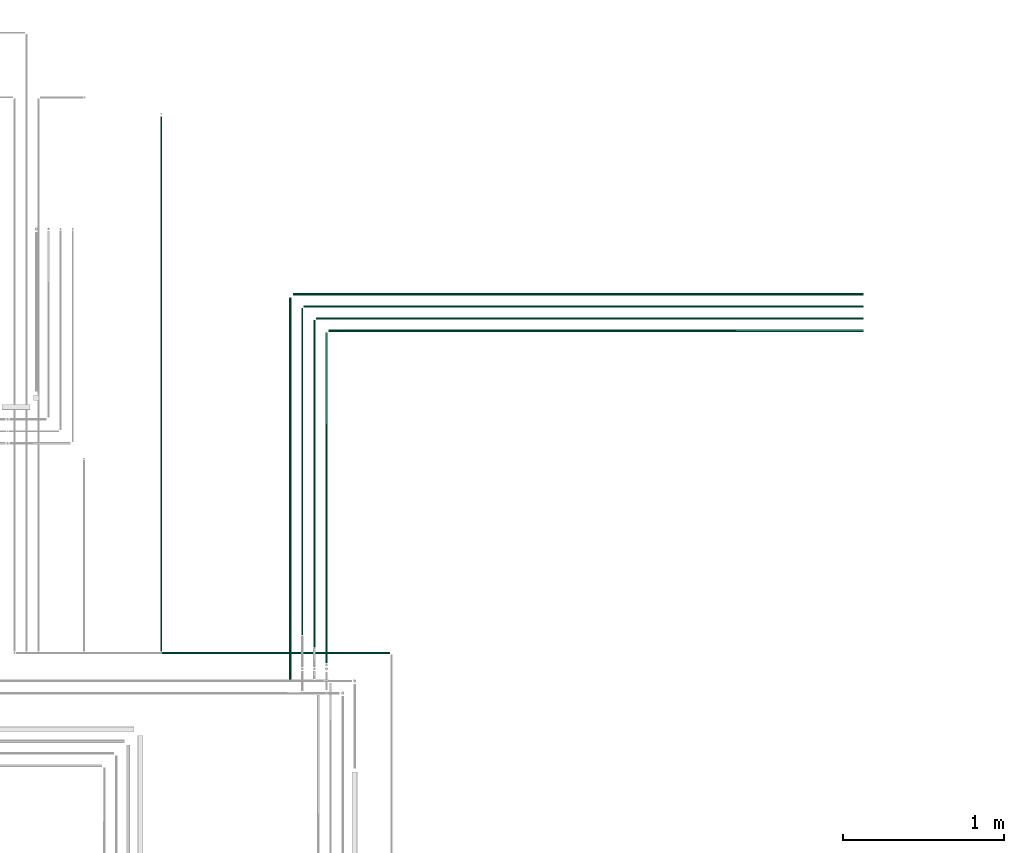
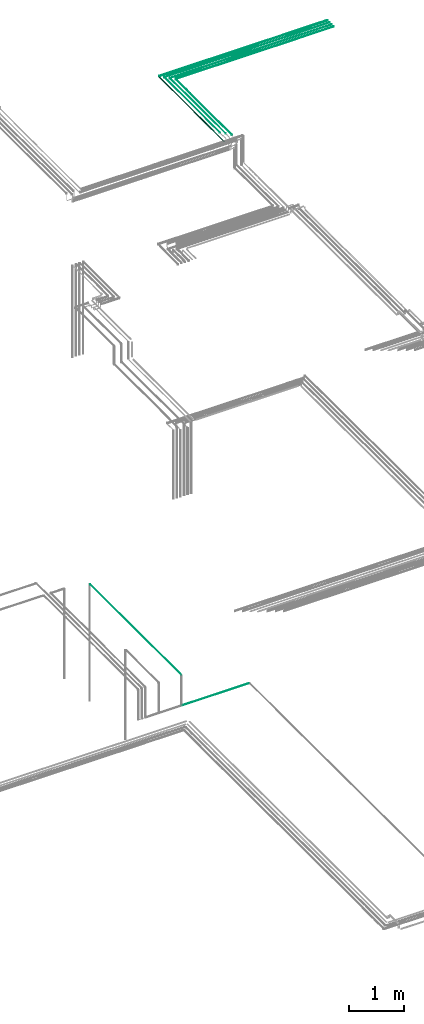
# One storey, part 114 of 331: 10 flow segments.
"""IFC2X3 building model written with IfcOpenShell, lengths in millimetres."""

from ifc_helpers import new_model, entity, si_unit, converted_unit, derived_unit, direction, frame, frame_2d, origin, origin_2d_with_axis, place, context, subcontext, project, spatial, circle, extrude, type_object, element, save


model = new_model("IFC2X3")

# Units and contexts
model_context = context("Model", 3, precision=0.01, world=origin(), true_north=direction((6.12303176911189e-17, 1.0)))
body_context = subcontext(model_context, "Body", "Model", "MODEL_VIEW")
ifc_project = project(units=[si_unit("LENGTHUNIT", "METRE", prefix="MILLI"), si_unit("AREAUNIT", "SQUARE_METRE"), si_unit("VOLUMEUNIT", "CUBIC_METRE"), converted_unit("PLANEANGLEUNIT", "DEGREE", entity("IfcRatioMeasure", 0.0174532925199433), si_unit("PLANEANGLEUNIT", "RADIAN"), dimensions=[0, 0, 0, 0, 0, 0, 0]), si_unit("MASSUNIT", "GRAM", prefix="KILO"), derived_unit("MASSDENSITYUNIT", [(si_unit("MASSUNIT", "GRAM", prefix="KILO"), 1), (si_unit("LENGTHUNIT", "METRE"), -3)]), derived_unit("MOMENTOFINERTIAUNIT", [(si_unit("LENGTHUNIT", "METRE"), 4)]), si_unit("TIMEUNIT", "SECOND"), si_unit("FREQUENCYUNIT", "HERTZ"), si_unit("THERMODYNAMICTEMPERATUREUNIT", "DEGREE_CELSIUS"), derived_unit("THERMALTRANSMITTANCEUNIT", [(si_unit("MASSUNIT", "GRAM", prefix="KILO"), 1), (si_unit("THERMODYNAMICTEMPERATUREUNIT", "KELVIN"), -1), (si_unit("TIMEUNIT", "SECOND"), -3)]), derived_unit("VOLUMETRICFLOWRATEUNIT", [(si_unit("LENGTHUNIT", "METRE"), 3), (si_unit("TIMEUNIT", "SECOND"), -1)]), derived_unit("MASSFLOWRATEUNIT", [(si_unit("MASSUNIT", "GRAM", prefix="KILO"), 1), (si_unit("TIMEUNIT", "SECOND"), -1)]), derived_unit("ROTATIONALFREQUENCYUNIT", [(si_unit("TIMEUNIT", "SECOND"), -1)]), si_unit("ELECTRICCURRENTUNIT", "AMPERE"), si_unit("ELECTRICVOLTAGEUNIT", "VOLT"), si_unit("POWERUNIT", "WATT"), si_unit("FORCEUNIT", "NEWTON", prefix="KILO"), si_unit("ILLUMINANCEUNIT", "LUX"), si_unit("LUMINOUSFLUXUNIT", "LUMEN"), si_unit("LUMINOUSINTENSITYUNIT", "CANDELA"), derived_unit("USERDEFINED", [(si_unit("MASSUNIT", "GRAM", prefix="KILO"), -1), (si_unit("LENGTHUNIT", "METRE"), -2), (si_unit("TIMEUNIT", "SECOND"), 3), (si_unit("LUMINOUSFLUXUNIT", "LUMEN"), 1)]), derived_unit("LINEARVELOCITYUNIT", [(si_unit("LENGTHUNIT", "METRE"), 1), (si_unit("TIMEUNIT", "SECOND"), -1)]), si_unit("PRESSUREUNIT", "PASCAL"), derived_unit("USERDEFINED", [(si_unit("LENGTHUNIT", "METRE"), -2), (si_unit("MASSUNIT", "GRAM", prefix="KILO"), 1), (si_unit("TIMEUNIT", "SECOND"), -2)]), derived_unit("LINEARFORCEUNIT", [(si_unit("MASSUNIT", "GRAM", prefix="KILO"), 1), (si_unit("LENGTHUNIT", "METRE"), 1), (si_unit("TIMEUNIT", "SECOND"), -2), (si_unit("LENGTHUNIT", "METRE"), -1)]), derived_unit("PLANARFORCEUNIT", [(si_unit("MASSUNIT", "GRAM", prefix="KILO"), 1), (si_unit("LENGTHUNIT", "METRE"), 1), (si_unit("TIMEUNIT", "SECOND"), -2), (si_unit("LENGTHUNIT", "METRE"), -2)])], contexts=[model_context])

# Site, building, storey
site_placement = place(None, frame((0.0, -0.00077364408347762, 0.0)))
site = spatial("IfcSite", under=ifc_project, at=site_placement, CompositionType="ELEMENT")
building_placement = place(site_placement, origin())
building = spatial("IfcBuilding", under=site, at=building_placement, CompositionType="ELEMENT")
storey_placement = place(building_placement, origin())
storey = spatial("IfcBuildingStorey", under=building, at=storey_placement, CompositionType="ELEMENT", Elevation=0.0)

# Flow segments
pipe_segment_type = type_object("IfcPipeSegmentType", PredefinedType="NOTDEFINED")
flow_segment_1_placement = place(building_placement, frame((61587.0947663298, 16133.1099669678, 19040.9047277641)))
element("IfcFlowSegment", 1, at=flow_segment_1_placement, inside=storey, type_object=pipe_segment_type, context=body_context, shape_type="SweptSolid", body=[
    extrude(circle(Radius=7.5, at=origin_2d_with_axis()), frame((9.09527223593152, 0.0, 9.09527223591636), z_axis=(0.0, 1.0, 0.0), x_axis=(1.0, 0.0, 0.0)), (0.0, 0.0, 1.0), 2373.88394202706),
])
flow_segment_2_placement = place(building_placement, frame((61614.1900385657, 18515.898636759, 19040.9047277641)))
element("IfcFlowSegment", 2, at=flow_segment_2_placement, inside=storey, type_object=pipe_segment_type, context=body_context, shape_type="SweptSolid", body=[
    extrude(circle(Radius=7.5, at=frame_2d((7.48597324544352e-42, -2.16573425859679e-12), x_axis=(1.0, 0.0))), frame((0.0, 9.09527223593369, 9.09527223591419), z_axis=(1.0, 0.0, 0.0), x_axis=(0.0, -1.0, 0.0)), (0.0, 0.0, 1.0), 3540.80979053584),
])
flow_segment_3_placement = place(storey_placement, frame((61813.5947663298, 16239.1356741211, 19042.4047277641)))
element("IfcFlowSegment", 3, at=flow_segment_3_placement, inside=storey, type_object=pipe_segment_type, context=body_context, shape_type="SweptSolid", body=[
    extrude(circle(Radius=6.0, at=frame_2d((2.59888111031614e-11, 0.0), x_axis=(1.0, 0.0))), frame((7.59527223593186, 0.0, 7.5952722359167), z_axis=(0.0, 1.0, 0.0), x_axis=(-1.0, 0.0, 0.0)), (0.0, 0.0, 1.0), 2046.85823487384),
])
flow_segment_4_placement = place(storey_placement, frame((61740.5947663298, 16334.4521787943, 19044.4047277641)))
element("IfcFlowSegment", 4, at=flow_segment_4_placement, inside=storey, type_object=pipe_segment_type, context=body_context, shape_type="SweptSolid", body=[
    extrude(circle(Radius=4.0, at=frame_2d((8.66293703438714e-12, 0.0), x_axis=(1.0, 0.0))), frame((5.59527223593232, 0.0, 5.59527223591499), z_axis=(0.0, 1.0, 0.0), x_axis=(-1.0, 0.0, 0.0)), (0.0, 0.0, 1.0), 2030.54173020063),
])
flow_segment_5_placement = place(storey_placement, frame((61665.5947663298, 16412.1300733041, 19044.4047277641)))
element("IfcFlowSegment", 5, at=flow_segment_5_placement, inside=storey, type_object=pipe_segment_type, context=body_context, shape_type="SweptSolid", body=[
    extrude(circle(Radius=4.0, at=frame_2d((8.66293703438714e-12, 0.0), x_axis=(1.0, 0.0))), frame((5.59527223593232, 0.0, 5.59527223591499), z_axis=(0.0, 1.0, 0.0), x_axis=(-1.0, 0.0, 0.0)), (0.0, 0.0, 1.0), 2027.86383569082),
])
flow_segment_6_placement = place(building_placement, frame((61835.1900385657, 18292.398636759, 19042.4047277641)))
element("IfcFlowSegment", 6, at=flow_segment_6_placement, inside=storey, type_object=pipe_segment_type, context=body_context, shape_type="SweptSolid", body=[
    extrude(circle(Radius=6.0, at=frame_2d((0.0, 2.16573425859679e-12), x_axis=(1.0, 0.0))), frame((0.0, 7.59527223593403, 7.59527223591887), z_axis=(1.0, 0.0, 0.0), x_axis=(0.0, -1.0, 0.0)), (0.0, 0.0, 1.0), 3319.80979053584),
])
flow_segment_7_placement = place(building_placement, frame((61756.1900385657, 18369.398636759, 19044.4047277641)))
element("IfcFlowSegment", 7, at=flow_segment_7_placement, inside=storey, type_object=pipe_segment_type, context=body_context, shape_type="SweptSolid", body=[
    extrude(circle(Radius=4.0, at=origin_2d_with_axis()), frame((0.0, 5.59527223593232, 5.59527223591499), z_axis=(1.0, 0.0, 0.0), x_axis=(0.0, -1.0, 0.0)), (0.0, 0.0, 1.0), 3398.80979053584),
])
flow_segment_8_placement = place(building_placement, frame((61681.1900385657, 18444.398636759, 19044.4047277641)))
element("IfcFlowSegment", 8, at=flow_segment_8_placement, inside=storey, type_object=pipe_segment_type, context=body_context, shape_type="SweptSolid", body=[
    extrude(circle(Radius=4.0, at=origin_2d_with_axis()), frame((0.0, 5.59527223593232, 5.59527223591499), z_axis=(1.0, 0.0, 0.0), x_axis=(0.0, -1.0, 0.0)), (0.0, 0.0, 1.0), 3473.80979053584),
])
flow_segment_9_placement = place(storey_placement, frame((60789.4049963188, 16308.5068408728, 7344.4047277641)))
element("IfcFlowSegment", 9, at=flow_segment_9_placement, inside=storey, type_object=pipe_segment_type, context=body_context, shape_type="SweptSolid", body=[
    extrude(circle(Radius=4.0, at=frame_2d((0.0, -1.08286712929839e-12), x_axis=(1.0, 0.0))), frame((5.59527223597563, 0.0, 5.59527223591499), z_axis=(0.0, 1.0, 0.0), x_axis=(1.0, 0.0, 0.0)), (0.0, 0.0, 1.0), 3320.79433560841),
])
flow_segment_10_placement = place(building_placement, frame((60800.0002685548, 16292.9115686369, 6669.40472776408)))
element("IfcFlowSegment", 10, at=flow_segment_10_placement, inside=storey, type_object=pipe_segment_type, context=body_context, shape_type="SweptSolid", body=[
    extrude(circle(Radius=4.0, at=frame_2d((6.49720277579036e-12, -1.08286712929839e-12), x_axis=(1.0, 0.0))), frame((0.0, 5.59527223591932, 5.59527223591716), z_axis=(1.0, 0.0, 0.0), x_axis=(0.0, 1.0, 0.0)), (0.0, 0.0, 1.0), 1414.99731445299),
])

save(model, "model.ifc")
